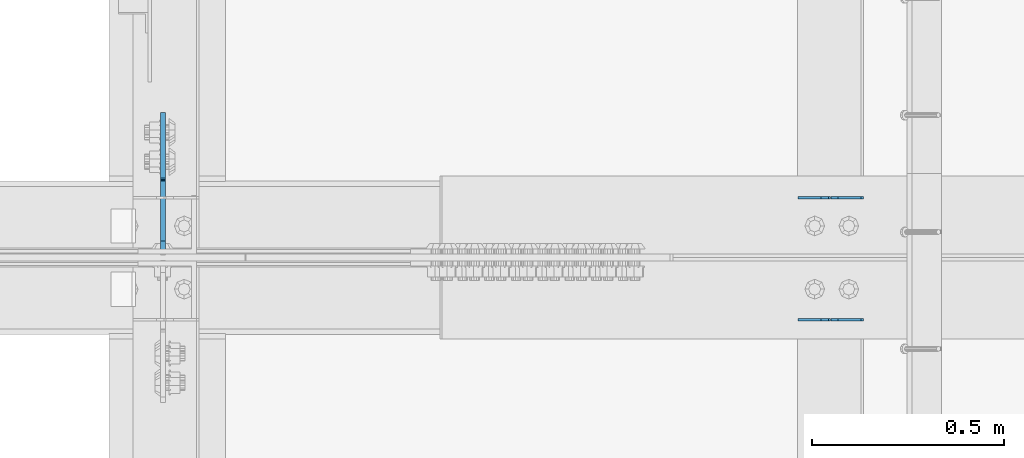
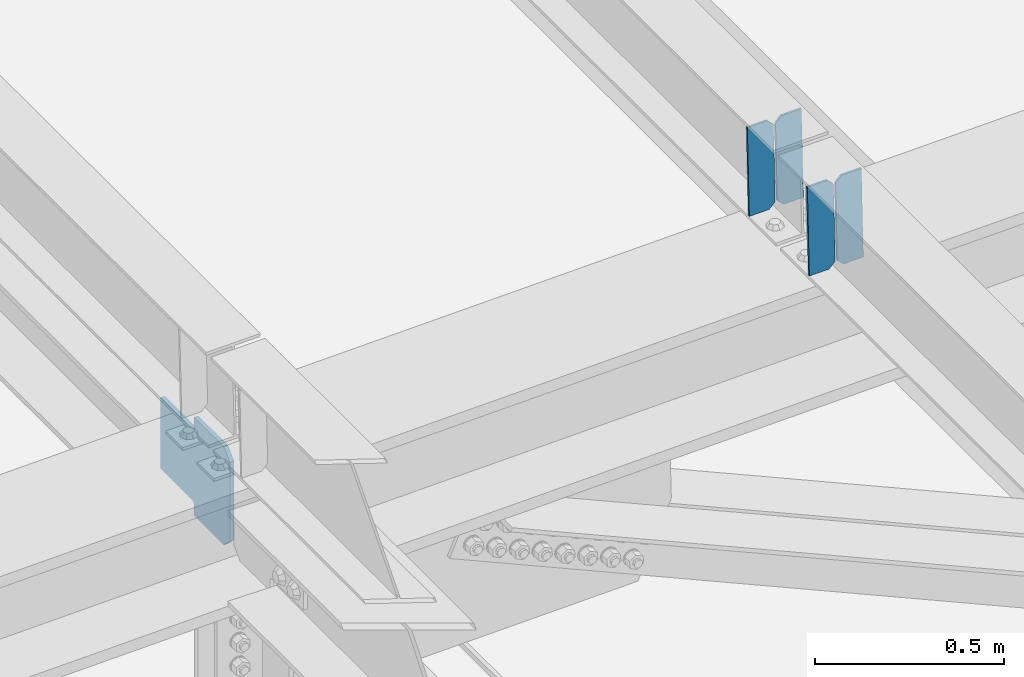
# One storey, part 3285 of 3843: 5 plates, 3 elements without a shape of their own.
"""IFC2X3 building model written with IfcOpenShell, lengths in millimetres."""

from ifc_helpers import new_model, si_unit, frame, origin_with_axes, place, context, subcontext, project, spatial, faceted_brep, material, type_object, element, aggregate, save


model = new_model("IFC2X3")

# Units and contexts
model_context = context("Model", 3, precision=1e-05, world=origin_with_axes())
body_context = subcontext(model_context, "Body", "Model", "MODEL_VIEW")
ifc_project = project(units=[si_unit("LENGTHUNIT", "METRE", prefix="MILLI"), si_unit("AREAUNIT", "SQUARE_METRE"), si_unit("VOLUMEUNIT", "CUBIC_METRE"), si_unit("MASSUNIT", "GRAM", prefix="KILO"), si_unit("TIMEUNIT", "SECOND"), si_unit("PLANEANGLEUNIT", "RADIAN"), si_unit("SOLIDANGLEUNIT", "STERADIAN"), si_unit("THERMODYNAMICTEMPERATUREUNIT", "DEGREE_CELSIUS"), si_unit("LUMINOUSINTENSITYUNIT", "LUMEN")], contexts=[model_context])

# Site, building, storey
site_placement = place(None, origin_with_axes())
site = spatial("IfcSite", under=ifc_project, at=site_placement, CompositionType="ELEMENT")
building_placement = place(site_placement, origin_with_axes())
building = spatial("IfcBuilding", under=site, at=building_placement, Name="Undefined", CompositionType="ELEMENT")
storey_placement = place(building_placement, origin_with_axes())
storey = spatial("IfcBuildingStorey", under=building, at=storey_placement, Name="Undefined", CompositionType="ELEMENT", Elevation=0.0)

# Assembly, plates
assembly_1_placement = place(storey_placement, origin_with_axes())
assembly_1 = element("IfcElementAssembly", 1, at=assembly_1_placement, inside=storey, Name="BEAM", AssemblyPlace="NOTDEFINED", PredefinedType="RIGID_FRAME")
ifc_material = material(Name="STEEL/A572-50")
plate_type_1 = type_object("IfcPlateType", PredefinedType="NOTDEFINED")
plate_1_placement = place(assembly_1_placement, frame((43878.2464740095, 59070.8426525861, 45623.9841696856), z_axis=(-0.0211520981315917, 0.000108436000053189, 0.999776263464114), x_axis=(-0.999776269342228, -3.16699999781408e-06, -0.0211520980072162)))
plate_1 = element("IfcPlate", 2, at=plate_1_placement, type_object=plate_type_1, material=ifc_material, Name="PLATE", context=body_context, shape_type="Brep", body=[
    faceted_brep([(0.0, -3.17499999999927, 0.0), (6.83940015733242e-10, -3.17499999996653, 288.924999998613), (6.54836185276508e-10, 3.17500000001746, 288.924999998591), (0.0, 3.17499999999927, 0.0), (60.3250007643655, -3.17500000017753, 288.924999998606), (60.3250007643219, 3.17499999979918, 288.924999998584), (79.3750000013097, -3.17500000025029, 269.875000761494), (79.375000001266, 3.17499999972642, 269.875000761487), (79.375000000713, -3.17500000026484, 19.0499992370605), (79.3750000006985, 3.17499999971187, 19.0499992370533), (60.325000763667, -3.17500000020664, -1.45519152283669e-11), (60.3250007636234, 3.17499999977736, -3.63797880709171e-11)], [[[0, 1, 2, 3]], [[1, 4, 5, 2]], [[4, 6, 7, 5]], [[6, 8, 9, 7]], [[8, 10, 11, 9]], [[10, 0, 3, 11]], [[5, 7, 9, 11, 3, 2]], [[10, 8, 6, 4, 1, 0]]]),
])
plate_2_placement = place(assembly_1_placement, frame((43792.5406533198, 59070.8424560034, 45622.1709060944), z_axis=(-0.0211520981315917, 0.000108436000053189, 0.999776263464114), x_axis=(-0.999776269342228, -3.16699999781408e-06, -0.0211520980072162)))
plate_2 = element("IfcPlate", 3, at=plate_2_placement, type_object=plate_type_1, material=ifc_material, Name="PLATE", context=body_context, shape_type="Brep", body=[
    faceted_brep([(4.36557456851006e-11, -3.17499999998836, 19.0499992370969), (6.11180439591408e-10, -3.17499999996653, 269.875000761516), (5.96628524363041e-10, 3.17500000001746, 269.875000761502), (1.45519152283669e-11, 3.17499999998836, 19.0499992370824), (19.0499992376572, -3.17500000003201, 288.924999998606), (19.0499992376281, 3.1749999999447, 288.924999998584), (79.3750000013242, -3.17500000025029, 288.924999998591), (79.3750000013097, 3.1749999997337, 288.92499999857), (79.3750000006548, -3.17500000026484, -2.18278728425503e-11), (79.3750000006403, 3.17499999969732, -2.91038304567337e-11), (19.0499992370023, -3.17500000005384, 0.0), (19.0499992369587, 3.17499999992287, -1.45519152283669e-11)], [[[0, 1, 2, 3]], [[1, 4, 5, 2]], [[4, 6, 7, 5]], [[6, 8, 9, 7]], [[8, 10, 11, 9]], [[10, 0, 3, 11]], [[5, 7, 9, 11, 3, 2]], [[10, 8, 6, 4, 1, 0]]]),
])
aggregate(assembly_1, [plate_1, plate_2])

assembly_2_placement = place(storey_placement, origin_with_axes())
assembly_2 = element("IfcElementAssembly", 4, at=assembly_2_placement, inside=storey, Name="BEAM", AssemblyPlace="NOTDEFINED", PredefinedType="RIGID_FRAME")
plate_3_placement = place(assembly_2_placement, frame((43878.2464700953, 58753.4069426247, 45623.9837031379), z_axis=(-0.0211520981284921, -0.000107078999957594, 0.999776263610439), x_axis=(-0.999776269342228, 3.1669999978437e-06, -0.0211520980072307)))
plate_3 = element("IfcPlate", 5, at=plate_3_placement, type_object=plate_type_1, material=ifc_material, Name="PLATE", context=body_context, shape_type="Brep", body=[
    faceted_brep([(0.0, -3.17499999999927, 0.0), (6.83940015733242e-10, -3.17499999996653, 288.924999998613), (6.54836185276508e-10, 3.17500000001746, 288.924999998591), (0.0, 3.17499999999927, 0.0), (60.3250007643655, -3.17500000017753, 288.924999998606), (60.3250007643219, 3.17499999979918, 288.924999998584), (79.3750000013097, -3.17500000025029, 269.875000761494), (79.375000001266, 3.17499999972642, 269.875000761487), (79.375000000713, -3.17500000026484, 19.0499992370605), (79.3750000006985, 3.17499999971187, 19.0499992370533), (60.325000763667, -3.17500000020664, -1.45519152283669e-11), (60.3250007636234, 3.17499999977736, -3.63797880709171e-11)], [[[0, 1, 2, 3]], [[1, 4, 5, 2]], [[4, 6, 7, 5]], [[6, 8, 9, 7]], [[8, 10, 11, 9]], [[10, 0, 3, 11]], [[5, 7, 9, 11, 3, 2]], [[10, 8, 6, 4, 1, 0]]]),
])
plate_4_placement = place(assembly_2_placement, frame((43792.540649406, 58753.4071367447, 45622.1704395484), z_axis=(-0.0211520981284921, -0.000107078999957594, 0.999776263610439), x_axis=(-0.999776269342228, 3.1669999978437e-06, -0.0211520980072307)))
plate_4 = element("IfcPlate", 6, at=plate_4_placement, type_object=plate_type_1, material=ifc_material, Name="PLATE", context=body_context, shape_type="Brep", body=[
    faceted_brep([(4.36557456851006e-11, -3.17499999998836, 19.0499992370969), (6.11180439591408e-10, -3.17499999996653, 269.875000761516), (5.96628524363041e-10, 3.17500000001746, 269.875000761502), (1.45519152283669e-11, 3.17499999998836, 19.0499992370824), (19.0499992376572, -3.17500000003201, 288.924999998606), (19.0499992376281, 3.1749999999447, 288.924999998584), (79.3750000013242, -3.17500000025029, 288.924999998591), (79.3750000013097, 3.1749999997337, 288.92499999857), (79.3750000006548, -3.17500000026484, -2.18278728425503e-11), (79.3750000006403, 3.17499999969732, -2.91038304567337e-11), (19.0499992370023, -3.17500000005384, 0.0), (19.0499992369587, 3.17499999992287, -1.45519152283669e-11)], [[[0, 1, 2, 3]], [[1, 4, 5, 2]], [[4, 6, 7, 5]], [[6, 8, 9, 7]], [[8, 10, 11, 9]], [[10, 0, 3, 11]], [[5, 7, 9, 11, 3, 2]], [[10, 8, 6, 4, 1, 0]]]),
])
aggregate(assembly_2, [plate_3, plate_4])

# Assembly, plate
assembly_3_placement = place(storey_placement, origin_with_axes())
assembly_3 = element("IfcElementAssembly", 7, at=assembly_3_placement, inside=storey, Name="BEAM", AssemblyPlace="NOTDEFINED", PredefinedType="RIGID_FRAME")
plate_type_2 = type_object("IfcPlateType", PredefinedType="NOTDEFINED")
plate_5_placement = place(assembly_3_placement, frame((42051.2875918738, 58926.4124998953, 45241.6176525136), z_axis=(0.0, 0.707106781186548, 0.707106781186548), x_axis=(5.70000238222118e-08, 0.707106781186546, -0.707106781186546)))
plate_5 = element("IfcPlate", 8, at=plate_5_placement, type_object=plate_type_2, material=ifc_material, Name="PLATE", context=body_context, shape_type="Brep", body=[
    faceted_brep([(0.0, -6.3499999046162, 0.0), (-179.447476957706, -6.34999999999854, 179.44747695771), (-179.447476957706, 6.34999999999854, 179.44747695771), (7.27595761418343e-12, 6.3499999046162, 0.0), (-179.447476957706, -6.34999999999854, 224.348757562839), (-179.447476957706, 6.34999999999854, 224.348757562839), (-68.3168074600108, -6.34999999999854, 335.479427060527), (-68.3168074600108, 6.34999999999854, 335.479427060527), (-46.1378915319801, -6.34999999999854, 313.300511132507), (-46.1378915319801, 6.34999999999854, 313.300511132507), (-42.0177150638483, -6.34999999999854, 310.547497232033), (-42.0177150638483, 6.34999999999854, 310.547497232033), (-37.1576355458092, -6.34999999999854, 309.580767309446), (-37.1576355458092, 6.34999999999854, 309.580767309446), (-32.29755602777, -6.34999999999854, 310.547497232033), (-32.29755602777, 6.34999999999854, 310.547497232033), (-28.1773795596382, -6.34999999999854, 313.300511132504), (-28.1773795596382, 6.34999999999854, 313.300511132504), (88.5659501485497, -6.34999999999854, 430.043840840692), (88.5659501485497, 6.34999999999854, 430.043840840692), (250.210560327017, -6.34999999999854, 268.39923066222), (250.210560327017, 6.34999999999854, 268.39923066222), (133.467230618844, -6.34999999999854, 151.655900954032), (133.467230618844, 6.34999999999854, 151.655900954032), (130.714216718363, -6.34999999999854, 147.53572448589), (130.714216718363, 6.34999999999854, 147.53572448589), (129.747486795779, -6.34999999999854, 142.675644967854), (129.747486795779, 6.34999999999854, 142.675644967854), (130.714216718363, -6.34999999999854, 137.815565449819), (130.714216718363, 6.34999999999854, 137.815565449819), (133.467230618844, -6.34999999999854, 133.695388981676), (133.467230618844, 6.34999999999854, 133.695388981676), (156.031950102829, -6.35000000000582, 111.130669497703), (156.031950102829, 6.35000000000582, 111.130669497703), (44.9012806051323, -6.35000000000582, -1.45519152283669e-11), (44.9012806051323, 6.35000000000582, -1.45519152283669e-11)], [[[0, 1, 2, 3]], [[1, 4, 5, 2]], [[4, 6, 7, 5]], [[6, 8, 9, 7]], [[8, 10, 11, 9]], [[10, 12, 13, 11]], [[12, 14, 15, 13]], [[14, 16, 17, 15]], [[16, 18, 19, 17]], [[18, 20, 21, 19]], [[20, 22, 23, 21]], [[22, 24, 25, 23]], [[24, 26, 27, 25]], [[26, 28, 29, 27]], [[28, 30, 31, 29]], [[30, 32, 33, 31]], [[32, 34, 35, 33]], [[34, 0, 3, 35]], [[5, 7, 9, 11, 13, 15, 17, 19, 21, 23, 25, 27, 29, 31, 33, 35, 3, 2]], [[34, 32, 30, 28, 26, 24, 22, 20, 18, 16, 14, 12, 10, 8, 6, 4, 1, 0]]]),
])
aggregate(assembly_3, [plate_5])

save(model, "model.ifc")
